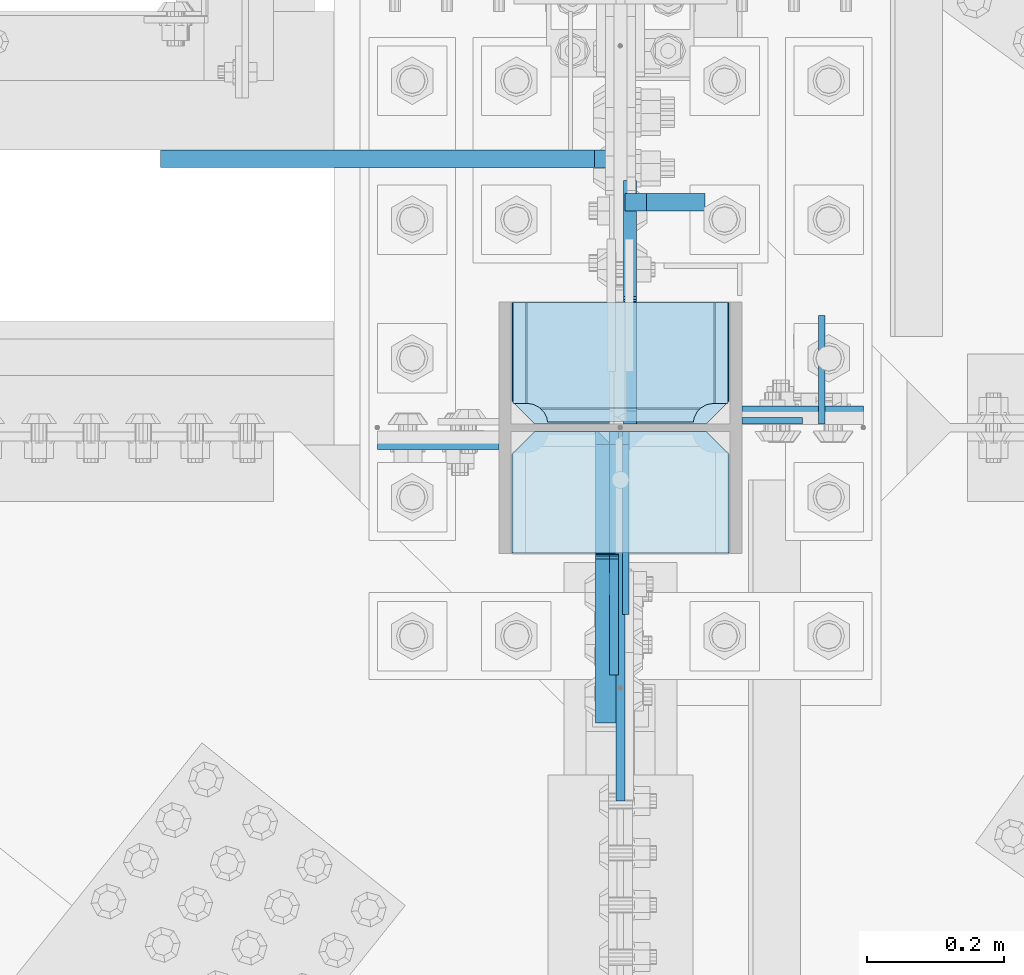
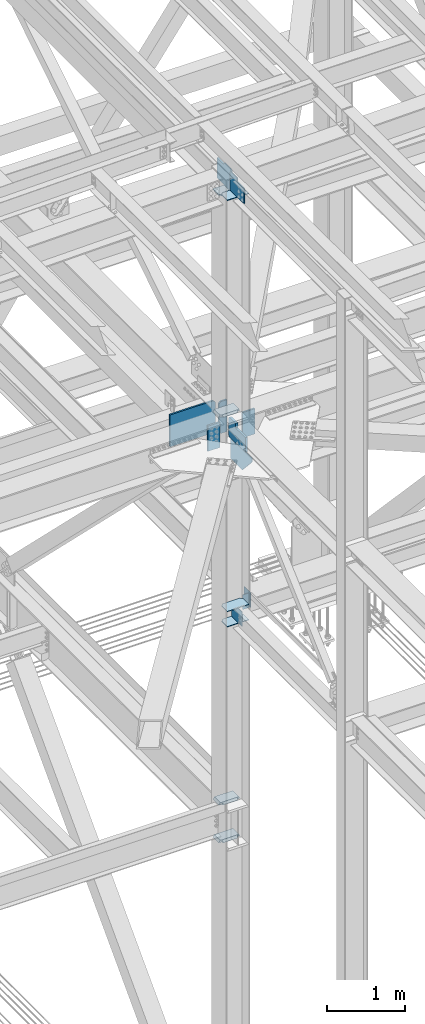
# One storey, part 3514 of 3843: 18 plates, 3 elements without a shape of their own.
"""IFC2X3 building model written with IfcOpenShell, lengths in millimetres."""

from ifc_helpers import new_model, si_unit, frame, origin_with_axes, place, context, subcontext, project, spatial, faceted_brep, material, type_object, element, aggregate, save


model = new_model("IFC2X3")

# Units and contexts
model_context = context("Model", 3, precision=1e-05, world=origin_with_axes())
body_context = subcontext(model_context, "Body", "Model", "MODEL_VIEW")
ifc_project = project(units=[si_unit("LENGTHUNIT", "METRE", prefix="MILLI"), si_unit("AREAUNIT", "SQUARE_METRE"), si_unit("VOLUMEUNIT", "CUBIC_METRE"), si_unit("MASSUNIT", "GRAM", prefix="KILO"), si_unit("TIMEUNIT", "SECOND"), si_unit("PLANEANGLEUNIT", "RADIAN"), si_unit("SOLIDANGLEUNIT", "STERADIAN"), si_unit("THERMODYNAMICTEMPERATUREUNIT", "DEGREE_CELSIUS"), si_unit("LUMINOUSINTENSITYUNIT", "LUMEN")], contexts=[model_context])

# Site, building, storey
site_placement = place(None, origin_with_axes())
site = spatial("IfcSite", under=ifc_project, at=site_placement, CompositionType="ELEMENT")
building_placement = place(site_placement, origin_with_axes())
building = spatial("IfcBuilding", under=site, at=building_placement, Name="Undefined", CompositionType="ELEMENT")
storey_placement = place(building_placement, origin_with_axes())
storey = spatial("IfcBuildingStorey", under=building, at=storey_placement, Name="Undefined", CompositionType="ELEMENT", Elevation=0.0)

# Assembly, plates
assembly_1_placement = place(storey_placement, origin_with_axes())
assembly_1 = element("IfcElementAssembly", 1, at=assembly_1_placement, inside=storey, Name="COLUMN", AssemblyPlace="NOTDEFINED", PredefinedType="RIGID_FRAME")
ifc_material = material(Name="STEEL/A572-50")
plate_type_1 = type_object("IfcPlateType", PredefinedType="NOTDEFINED")
plate_1_placement = place(assembly_1_placement, frame((76854.05, 92031.34375, 45946.8205507418), z_axis=(1.0, 0.0, 0.0), x_axis=(0.0, 1.0, 0.0)))
plate_1 = element("IfcPlate", 2, at=plate_1_placement, type_object=plate_type_1, material=ifc_material, Name="PLATE", context=body_context, shape_type="Brep", body=[
    faceted_brep([(0.0, -6.3499999046162, 0.0), (0.0, -6.34999999999854, 317.5), (0.0, 6.34999999999854, 317.5), (7.27595761418343e-12, 6.3499999046162, 0.0), (144.462501525879, -6.34999999999854, 317.5), (144.462501525879, 6.34999999999854, 317.5), (177.800003051758, -6.34999999999854, 284.162498474121), (177.800003051758, 6.34999999999854, 284.162498474121), (177.800003051758, -6.34999999999854, 33.3375015258789), (177.800003051758, 6.34999999999854, 33.3375015258789), (144.462501525879, -6.34999999999854, 0.0), (144.462501525879, 6.34999999999854, 0.0)], [[[0, 1, 2, 3]], [[1, 4, 5, 2]], [[4, 6, 7, 5]], [[6, 8, 9, 7]], [[8, 10, 11, 9]], [[10, 0, 3, 11]], [[5, 7, 9, 11, 3, 2]], [[10, 8, 6, 4, 1, 0]]]),
])
plate_type_2 = type_object("IfcPlateType", PredefinedType="NOTDEFINED")
plate_2_placement = place(assembly_1_placement, frame((76835.0, 92195.65, 42411.65), z_axis=(-1.0, 0.0, 0.0), x_axis=(0.0, 0.0, -1.0)))
plate_2 = element("IfcPlate", 3, at=plate_2_placement, type_object=plate_type_2, material=ifc_material, Name="PLATE", context=body_context, shape_type="Brep", body=[
    faceted_brep([(0.0, -12.6999999999971, 0.0), (4.36557456851006e-11, -12.7000000000171, 177.800000000003), (-1.45519152283669e-11, 12.7000000000025, 177.800000000003), (0.0, 12.6999999999971, 0.0), (393.700012207031, -12.7000000000007, 177.800003051758), (393.700012207031, 12.7000000000007, 177.800003051758), (393.700012207031, -12.7000000000007, 0.0), (393.700012207031, 12.7000000000007, 0.0)], [[[0, 1, 2, 3]], [[1, 4, 5, 2]], [[4, 6, 7, 5]], [[6, 0, 3, 7]], [[5, 7, 3, 2]], [[6, 4, 1, 0]]]),
])
plate_3_placement = place(assembly_1_placement, frame((77190.6, 92233.75, 42411.65), z_axis=(1.0, 0.0, 0.0), x_axis=(0.0, 0.0, -1.0)))
plate_3 = element("IfcPlate", 4, at=plate_3_placement, type_object=plate_type_2, material=ifc_material, Name="PLATE", context=body_context, shape_type="Brep", body=[
    faceted_brep([(0.0, -12.6999999999971, 0.0), (4.36557456851006e-11, -12.7000000000171, 177.800000000003), (-1.45519152283669e-11, 12.7000000000025, 177.800000000003), (0.0, 12.6999999999971, 0.0), (393.700012207031, -12.7000000000007, 177.800003051758), (393.700012207031, 12.7000000000007, 177.800003051758), (393.700012207031, -12.7000000000007, 0.0), (393.700012207031, 12.7000000000007, 0.0)], [[[0, 1, 2, 3]], [[1, 4, 5, 2]], [[4, 6, 7, 5]], [[6, 0, 3, 7]], [[5, 7, 3, 2]], [[6, 4, 1, 0]]]),
])
plate_type_3 = type_object("IfcPlateType", PredefinedType="NOTDEFINED")
plate_4_placement = place(assembly_1_placement, frame((77190.6, 92225.01875, 39573.2), z_axis=(1.0, 0.0, 0.0), x_axis=(0.0, 0.0, -1.0)))
plate_4 = element("IfcPlate", 5, at=plate_4_placement, type_object=plate_type_3, material=ifc_material, Name="PLATE", context=body_context, shape_type="Brep", body=[
    faceted_brep([(0.0, -4.76249999999709, 0.0), (0.0, -4.76249999999709, 88.9000015258789), (0.0, 4.76249999999709, 88.9000015258789), (0.0, 4.76249999999709, 0.0), (228.600006102781, -4.7625000004191, 88.9000015257589), (228.600006102781, 4.76249999954598, 88.9000015257443), (228.600006103079, -4.7625000004482, 7.27595761418343e-12), (228.600006103079, 4.76249999954598, -7.27595761418343e-12)], [[[0, 1, 2, 3]], [[1, 4, 5, 2]], [[4, 6, 7, 5]], [[6, 0, 3, 7]], [[5, 7, 3, 2]], [[6, 4, 1, 0]]]),
])
plate_type_4 = type_object("IfcPlateType", PredefinedType="NOTDEFINED")
plate_5_placement = place(assembly_1_placement, frame((76854.05, 92031.34375, 39308.0875), z_axis=(1.0, 0.0, 0.0), x_axis=(0.0, 1.0, 0.0)))
plate_5 = element("IfcPlate", 6, at=plate_5_placement, type_object=plate_type_4, material=ifc_material, Name="PLATE", context=body_context, shape_type="Brep", body=[
    faceted_brep([(0.0, -4.76249999999709, 0.0), (0.0, -4.76249999785796, 317.500000005042), (0.0, 4.76250000210712, 317.50000000505), (0.0, 4.76249999999709, 0.0), (144.462501525879, -4.76249999999709, 317.5), (144.462501525879, 4.76249999999709, 317.5), (177.800003051758, -4.76249999999709, 284.162498474121), (177.800003051758, 4.76249999999709, 284.162498474121), (177.800003051758, -4.76249999999709, 33.3375015258789), (177.800003051758, 4.76249999999709, 33.3375015258789), (144.462501525879, -4.76249999999709, 0.0), (144.462501525879, 4.76249999999709, 0.0)], [[[0, 1, 2, 3]], [[1, 4, 5, 2]], [[4, 6, 7, 5]], [[6, 8, 9, 7]], [[8, 10, 11, 9]], [[10, 0, 3, 11]], [[5, 7, 9, 11, 3, 2]], [[10, 8, 6, 4, 1, 0]]]),
])
plate_6_placement = place(assembly_1_placement, frame((76854.05, 92031.34375, 39546.2125), z_axis=(1.0, 0.0, 0.0), x_axis=(0.0, 1.0, 0.0)))
plate_6 = element("IfcPlate", 7, at=plate_6_placement, type_object=plate_type_4, material=ifc_material, Name="PLATE", context=body_context, shape_type="Brep", body=[
    faceted_brep([(0.0, -4.76249999999709, 0.0), (0.0, -4.76249999785796, 317.500000005042), (0.0, 4.76250000210712, 317.50000000505), (0.0, 4.76249999999709, 0.0), (144.462501525879, -4.76249999999709, 317.5), (144.462501525879, 4.76249999999709, 317.5), (177.800003051758, -4.76249999999709, 284.162498474121), (177.800003051758, 4.76249999999709, 284.162498474121), (177.800003051758, -4.76249999999709, 33.3375015258789), (177.800003051758, 4.76249999999709, 33.3375015258789), (144.462501525879, -4.76249999999709, 0.0), (144.462501525879, 4.76249999999709, 0.0)], [[[0, 1, 2, 3]], [[1, 4, 5, 2]], [[4, 6, 7, 5]], [[6, 8, 9, 7]], [[8, 10, 11, 9]], [[10, 0, 3, 11]], [[5, 7, 9, 11, 3, 2]], [[10, 8, 6, 4, 1, 0]]]),
])
plate_type_5 = type_object("IfcPlateType", PredefinedType="NOTDEFINED")
plate_7_placement = place(assembly_1_placement, frame((77173.1375, 92398.05625, 42452.925), z_axis=(-1.0, 0.0, 0.0), x_axis=(0.0, -1.0, 0.0)))
plate_7 = element("IfcPlate", 8, at=plate_7_placement, type_object=plate_type_5, material=ifc_material, Name="PLATE", context=body_context, shape_type="Brep", body=[
    faceted_brep([(160.070927103505, 9.33349681380787, 48.2144734940957), (156.294129000915, 15.875, 44.437675391513), (156.294129000915, 15.875, 276.23732460849), (160.070927103505, 9.33349681380787, 272.460526505907), (168.479274789282, -5.2299592362906, 268.176259371801), (174.625000047687, -15.875, 267.202872116366), (174.625000047687, -15.875, 53.4721278836369), (168.479274789282, -5.2299592362906, 52.4987406282016), (147.63749961853, 15.875, 21.5053709990898), (147.63749961853, -15.875, 3.17449995232164), (0.0, -15.875, 3.17449995232164), (0.0, 15.875, 21.5053709990898), (0.0, 15.875, 299.168629000924), (0.0, -15.875, 317.499500047692), (147.63749961853, -15.875, 317.499500047692), (147.63749961853, 15.875, 299.168629000924), (147.63749961853, -15.875, 296.862501907352), (147.63749961853, 15.875, 296.862501907352), (149.113757464445, -15.875, 287.541776696642), (149.113757464445, 15.875, 287.541776696642), (153.398024598548, -15.875, 279.133429010864), (153.398024598548, 15.875, 279.133429010864), (160.070927103505, -15.875, 272.460526505907), (168.479274789282, -15.875, 268.176259371801), (168.479274789282, -15.875, 52.4987406282016), (160.070927103505, -15.875, 48.2144734940957), (153.398024598548, -15.875, 41.5415709891386), (153.398024598548, 15.875, 41.5415709891386), (149.113757464449, -15.875, 33.1332233033609), (149.113757464449, 15.875, 33.1332233033609), (147.63749961853, -15.875, 23.8124980926514), (147.63749961853, 15.875, 23.8124980926514)], [[[0, 1, 2, 3, 4, 5, 6, 7]], [[8, 9, 10, 11]], [[12, 13, 14, 15]], [[13, 12, 11, 10]], [[16, 17, 15, 14]], [[16, 18, 19, 17]], [[18, 20, 21, 19]], [[21, 20, 22, 3, 2]], [[22, 23, 4, 3]], [[23, 5, 4]], [[24, 7, 6]], [[24, 25, 0, 7]], [[25, 26, 27, 1, 0]], [[26, 28, 29, 27]], [[28, 30, 31, 29]], [[31, 30, 9, 8]], [[27, 29, 31, 8, 11, 12, 15, 17, 19, 21, 2, 1]], [[9, 30, 28, 26, 25, 24, 6, 5, 23, 22, 20, 18, 16, 14, 13, 10]]]),
])
plate_type_6 = type_object("IfcPlateType", PredefinedType="NOTDEFINED")
plate_8_placement = place(assembly_1_placement, frame((77171.55, 92398.05625, 45902.4145639776), z_axis=(-1.0, 0.0, 0.0), x_axis=(0.0, -1.0, 0.0)))
plate_8 = element("IfcPlate", 9, at=plate_8_placement, type_object=plate_type_6, material=ifc_material, Name="PLATE", context=body_context, shape_type="Brep", body=[
    faceted_brep([(0.0, -9.52500000000146, 0.0), (0.0, -9.52500000000146, 317.5), (0.0, 9.52500000000146, 317.5), (0.0, 9.52500000000146, 0.0), (144.462501525879, -9.52500000000146, 317.5), (144.462501525879, 9.52500000000146, 317.5), (177.800003051758, -9.52500000000146, 284.162498474121), (177.800003051758, 9.52500000000146, 284.162498474121), (177.800003051758, -9.52500000000146, 33.3375015258789), (177.800003051758, 9.52500000000146, 33.3375015258789), (144.462501525879, -9.52500000000146, 0.0), (144.462501525879, 9.52500000000146, 0.0)], [[[0, 1, 2, 3]], [[1, 4, 5, 2]], [[4, 6, 7, 5]], [[6, 8, 9, 7]], [[8, 10, 11, 9]], [[10, 0, 3, 11]], [[5, 7, 9, 11, 3, 2]], [[10, 8, 6, 4, 1, 0]]]),
])
plate_type_7 = type_object("IfcPlateType", PredefinedType="NOTDEFINED")
plate_9_placement = place(assembly_1_placement, frame((77020.7375, 92209.14375, 39331.9), z_axis=(0.0, -0.707106781186682, 0.707106781186413), x_axis=(0.0, -0.707106781186548, -0.707106781186548)))
plate_9 = element("IfcPlate", 10, at=plate_9_placement, type_object=plate_type_7, material=ifc_material, Name="PLATE", context=body_context, shape_type="Brep", body=[
    faceted_brep([(0.0, -4.76249999999709, 0.0), (-134.703841815408, -4.76249999999709, 134.703841815382), (-134.703841815408, 4.76249999999709, 134.703841815382), (0.0, 4.76249999999709, 0.0), (-134.703841815266, -4.76249999999709, 161.644610178599), (-134.703841815266, 4.76249999999709, 161.644610178599), (40.9724185541018, -4.76249999999709, 337.320870548006), (40.9724185541018, 4.76249999999709, 337.320870548006), (202.617028732588, -4.76249999999709, 175.676260369546), (202.617028732588, 4.76249999999709, 175.676260369546), (26.9407683631998, -4.76249999999709, 1.30967237055302e-10), (26.9407683631998, 4.76249999999709, 1.30967237055302e-10)], [[[0, 1, 2, 3]], [[1, 4, 5, 2]], [[4, 6, 7, 5]], [[6, 8, 9, 7]], [[8, 10, 11, 9]], [[10, 0, 3, 11]], [[5, 7, 9, 11, 3, 2]], [[10, 8, 6, 4, 1, 0]]]),
])
plate_type_8 = type_object("IfcPlateType", PredefinedType="NOTDEFINED")
plate_10_placement = place(assembly_1_placement, frame((77173.1375, 92398.05625, 35831.4625), z_axis=(-1.0, 0.0, 0.0), x_axis=(0.0, -1.0, 0.0)))
plate_10 = element("IfcPlate", 11, at=plate_10_placement, type_object=plate_type_8, material=ifc_material, Name="PLATE", context=body_context, shape_type="Brep", body=[
    faceted_brep([(160.070930155271, 7.74588927352306, 48.2144734940957), (154.461042336727, 17.4625000000015, 42.6045856755663), (154.461042336727, 17.4625000000015, 278.070402117402), (160.070930155271, 7.74588927353034, 272.460514298873), (168.479277841048, -6.81779612594255, 268.176247164767), (174.625000047687, -17.4625000000015, 267.202860392674), (174.625000047687, -17.4625000000015, 53.472127400295), (168.479277841048, -6.81779612594255, 52.4987406282016), (147.637502670288, 17.4625000000015, 23.3384576632816), (147.637502670288, -17.4625000000015, 3.17449995232164), (0.0, -17.4625000000015, 3.17449995232164), (0.0, 17.4625000000015, 23.3384576632816), (0.0, 17.4625000000015, 297.335542336732), (0.0, -17.4625000000015, 317.499500047692), (147.637502670288, -17.4625000000015, 317.499500047692), (147.637502670288, 17.4625000000015, 297.335542336732), (147.637502670288, -17.4625000000015, 296.862489700317), (147.637502670288, 17.4625000000015, 296.862489700317), (149.113760516208, -17.4625000000015, 287.541764489608), (149.113760516208, 17.4625000000015, 287.541764489608), (153.398027650313, -17.4625000000015, 279.13341680383), (153.398027650313, 17.4625000000015, 279.13341680383), (160.070930155271, -17.4625000000015, 272.460514298873), (168.479277841048, -17.4625000000015, 268.176247164767), (168.479277841048, -17.4625000000015, 52.4987406282016), (160.070930155271, -17.4625000000015, 48.2144734940957), (153.398027650313, -17.4625000000015, 41.5415709891386), (153.398027650313, 17.4625000000015, 41.5415709891386), (149.113760516208, -17.4625000000015, 33.1332233033609), (149.113760516208, 17.4625000000015, 33.1332233033609), (147.637502670288, -17.4625000000015, 23.8124980926514), (147.637502670288, 17.4625000000015, 23.8124980926514)], [[[0, 1, 2, 3, 4, 5, 6, 7]], [[8, 9, 10, 11]], [[12, 13, 14, 15]], [[13, 12, 11, 10]], [[16, 17, 15, 14]], [[16, 18, 19, 17]], [[18, 20, 21, 19]], [[21, 20, 22, 3, 2]], [[22, 23, 4, 3]], [[23, 5, 4]], [[24, 7, 6]], [[24, 25, 0, 7]], [[25, 26, 27, 1, 0]], [[26, 28, 29, 27]], [[28, 30, 31, 29]], [[31, 30, 9, 8]], [[27, 29, 31, 8, 11, 12, 15, 17, 19, 21, 2, 1]], [[9, 30, 28, 26, 25, 24, 6, 5, 23, 22, 20, 18, 16, 14, 13, 10]]]),
])
plate_11_placement = place(assembly_1_placement, frame((77173.1375, 92398.05625, 36418.8375), z_axis=(-1.0, 0.0, 0.0), x_axis=(0.0, -1.0, 0.0)))
plate_11 = element("IfcPlate", 12, at=plate_11_placement, type_object=plate_type_8, material=ifc_material, Name="PLATE", context=body_context, shape_type="Brep", body=[
    faceted_brep([(160.070930155271, 7.74588927352306, 48.2144734940957), (154.461042336727, 17.4625000000015, 42.6045856755663), (154.461042336727, 17.4625000000015, 278.070402117402), (160.070930155271, 7.74588927353034, 272.460514298873), (168.479277841048, -6.81779612594255, 268.176247164767), (174.625000047687, -17.4625000000015, 267.202860392674), (174.625000047687, -17.4625000000015, 53.472127400295), (168.479277841048, -6.81779612594255, 52.4987406282016), (147.637502670288, 17.4625000000015, 23.3384576632816), (147.637502670288, -17.4625000000015, 3.17449995232164), (0.0, -17.4625000000015, 3.17449995232164), (0.0, 17.4625000000015, 23.3384576632816), (0.0, 17.4625000000015, 297.335542336732), (0.0, -17.4625000000015, 317.499500047692), (147.637502670288, -17.4625000000015, 317.499500047692), (147.637502670288, 17.4625000000015, 297.335542336732), (147.637502670288, -17.4625000000015, 296.862489700317), (147.637502670288, 17.4625000000015, 296.862489700317), (149.113760516208, -17.4625000000015, 287.541764489608), (149.113760516208, 17.4625000000015, 287.541764489608), (153.398027650313, -17.4625000000015, 279.13341680383), (153.398027650313, 17.4625000000015, 279.13341680383), (160.070930155271, -17.4625000000015, 272.460514298873), (168.479277841048, -17.4625000000015, 268.176247164767), (168.479277841048, -17.4625000000015, 52.4987406282016), (160.070930155271, -17.4625000000015, 48.2144734940957), (153.398027650313, -17.4625000000015, 41.5415709891386), (153.398027650313, 17.4625000000015, 41.5415709891386), (149.113760516208, -17.4625000000015, 33.1332233033609), (149.113760516208, 17.4625000000015, 33.1332233033609), (147.637502670288, -17.4625000000015, 23.8124980926514), (147.637502670288, 17.4625000000015, 23.8124980926514)], [[[0, 1, 2, 3, 4, 5, 6, 7]], [[8, 9, 10, 11]], [[12, 13, 14, 15]], [[13, 12, 11, 10]], [[16, 17, 15, 14]], [[16, 18, 19, 17]], [[18, 20, 21, 19]], [[21, 20, 22, 3, 2]], [[22, 23, 4, 3]], [[23, 5, 4]], [[24, 7, 6]], [[24, 25, 0, 7]], [[25, 26, 27, 1, 0]], [[26, 28, 29, 27]], [[28, 30, 31, 29]], [[31, 30, 9, 8]], [[27, 29, 31, 8, 11, 12, 15, 17, 19, 21, 2, 1]], [[9, 30, 28, 26, 25, 24, 6, 5, 23, 22, 20, 18, 16, 14, 13, 10]]]),
])
plate_type_9 = type_object("IfcPlateType", PredefinedType="NOTDEFINED")
plate_12_placement = place(assembly_1_placement, frame((77012.7999997492, 92209.1437500256, 42092.5625000007), z_axis=(0.0, 0.0, -1.0), x_axis=(0.0, -1.0, 0.0)))
plate_12 = element("IfcPlate", 13, at=plate_12_placement, type_object=plate_type_9, material=ifc_material, Name="PLATE", context=body_context, shape_type="Brep", body=[
    faceted_brep([(19.0499992370605, -6.34999999999854, 0.0), (0.0, -6.34999999999854, 19.0499992370605), (0.0, 6.34999999999854, 19.0499992370605), (19.0499992370605, 6.34999999999854, 0.0), (0.0, -6.35000000000582, 323.518849143686), (292.362207107595, -6.35000000000582, 323.518849143686), (292.362207107595, 6.35000000000582, 323.518849143686), (0.0, 6.35000000000582, 323.518849143686), (540.371308423739, -6.35000000000582, 51.2388908941648), (540.371308423739, 6.35000000000582, 51.2388908941648), (540.371308423739, -6.35000000000582, 0.0), (540.371308423739, 6.35000000000582, 0.0)], [[[0, 1, 2, 3]], [[4, 5, 6, 7]], [[5, 8, 9, 6]], [[8, 10, 11, 9]], [[11, 10, 0, 3]], [[7, 6, 9, 11, 3, 2]], [[4, 7, 2, 1]], [[10, 8, 5, 4, 1, 0]]]),
])
plate_type_10 = type_object("IfcPlateType", PredefinedType="NOTDEFINED")
plate_13_placement = place(assembly_1_placement, frame((76992.1625, 92209.14375, 42143.3625), z_axis=(0.0, -0.707106781186682, 0.707106781186413), x_axis=(0.0, -0.707106781186548, -0.707106781186548)))
plate_13 = element("IfcPlate", 14, at=plate_13_placement, type_object=plate_type_10, material=ifc_material, Name="PLATE", context=body_context, shape_type="Brep", body=[
    faceted_brep([(-187.462669209825, 15.875, 227.874176387639), (33.6761377704388, 15.875, 6.7353694073754), (26.9407683633472, 6.34991590662685, 2.7648638933897e-10), (0.0, -12.6997507629567, 7.27595761418343e-12), (-194.198038617193, -12.6997507629567, 194.198038617193), (-194.198038616931, 6.34991590662685, 221.138806980547), (0.0, -15.875, 0.0), (-194.198038617162, -15.875, 194.1980386172), (-194.198038617162, -15.875, 221.138806980285), (-81.3835710967596, -15.875, 333.953274500665), (-81.3835710967596, 15.875, 333.953274500665), (-37.6048223719172, -15.875, 290.174525775801), (-37.6048223719172, 15.875, 290.174525775801), (-33.4846459037744, -15.875, 287.421511875335), (-33.4846459037744, 15.875, 287.421511875335), (-28.6245663857389, -15.875, 286.454781952751), (-28.6245663857389, 15.875, 286.454781952751), (-23.7644868676998, -15.875, 287.421511875335), (-23.7644868676998, 15.875, 287.421511875335), (-19.6443103995607, -15.875, 290.174525775801), (-19.6443103995607, 15.875, 290.174525775801), (146.490427980447, -15.875, 456.30926415584), (146.490427980447, 15.875, 456.30926415584), (308.1350381589, -15.875, 294.664653977386), (308.1350381589, 15.875, 294.664653977386), (139.755235613762, -15.875, 126.284851432189), (139.755235613762, 15.875, 126.284851432189), (137.69047524009, -15.875, 123.194719158433), (137.69047524009, 15.875, 123.194719158433), (136.965427816298, -15.875, 119.549659611148), (136.965427816298, 15.875, 119.549659611148), (137.690475240086, -15.875, 115.904600063863), (137.690475240086, 15.875, 115.904600063863), (139.755235883486, -15.875, 112.814467520366), (139.755235883486, 15.875, 112.814467520366), (26.9407683630798, -15.875, 0.0)], [[[0, 1, 2, 3, 4, 5]], [[6, 7, 4, 3]], [[7, 8, 5, 4]], [[8, 9, 10, 0, 5]], [[9, 11, 12, 10]], [[11, 13, 14, 12]], [[13, 15, 16, 14]], [[15, 17, 18, 16]], [[17, 19, 20, 18]], [[19, 21, 22, 20]], [[21, 23, 24, 22]], [[23, 25, 26, 24]], [[25, 27, 28, 26]], [[27, 29, 30, 28]], [[29, 31, 32, 30]], [[31, 33, 34, 32]], [[34, 33, 35, 2, 1]], [[35, 6, 3, 2]], [[10, 12, 14, 16, 18, 20, 22, 24, 26, 28, 30, 32, 34, 1, 0]], [[35, 33, 31, 29, 27, 25, 23, 21, 19, 17, 15, 13, 11, 9, 8, 7, 6]]]),
])

# Assembly, plate
assembly_2_placement = place(storey_placement, origin_with_axes())
assembly_2 = element("IfcElementAssembly", 15, at=assembly_2_placement, inside=storey, Name="BEAM", AssemblyPlace="NOTDEFINED", PredefinedType="RIGID_FRAME")
plate_type_11 = type_object("IfcPlateType", PredefinedType="NOTDEFINED")
plate_14_placement = place(assembly_2_placement, frame((77307.28125, 92220.25625, 39570.025), z_axis=(0.0, 1.0, 0.0), x_axis=(0.0, 0.0, -1.0)))
plate_14 = element("IfcPlate", 16, at=plate_14_placement, type_object=plate_type_11, material=ifc_material, Name="PLATE", context=body_context, shape_type="Brep", body=[
    faceted_brep([(0.0, -4.76249999999709, 0.0), (0.0, -4.76249999999709, 158.749999526888), (0.0, 4.76249999999709, 158.749999526888), (0.0, 4.76249999999709, 0.0), (228.599999999999, -4.76249999999709, 158.749999526888), (228.599999999999, 4.76249999999709, 158.749999526888), (228.600006103079, -4.7625000004482, 7.27595761418343e-12), (228.600006103079, 4.76249999954598, -7.27595761418343e-12)], [[[0, 1, 2, 3]], [[1, 4, 5, 2]], [[4, 6, 7, 5]], [[6, 0, 3, 7]], [[5, 7, 3, 2]], [[6, 4, 1, 0]]]),
])
aggregate(assembly_2, [plate_14])

# Assembly, plates
assembly_3_placement = place(storey_placement, origin_with_axes())
assembly_3 = element("IfcElementAssembly", 17, at=assembly_3_placement, inside=storey, Name="BEAM", AssemblyPlace="NOTDEFINED", PredefinedType="RIGID_FRAME")
plate_type_12 = type_object("IfcPlateType", PredefinedType="NOTDEFINED")
plate_15_placement = place(assembly_3_placement, frame((77136.625, 92544.9, 41948.1), z_axis=(0.0, 0.0, 1.0), x_axis=(-1.0, 0.0, 0.0)))
plate_15 = element("IfcPlate", 18, at=plate_15_placement, type_object=plate_type_12, material=ifc_material, Name="STIFFENER", context=body_context, shape_type="Brep", body=[
    faceted_brep([(0.0, -12.6999999999971, 0.0), (0.0, -12.6999999999971, 498.474999999999), (0.0, 12.6999999999971, 498.474999999999), (0.0, 12.6999999999971, 0.0), (85.7249999999913, -12.6999999999971, 498.474999999999), (85.7249999999913, 12.6999999999971, 498.474999999999), (117.474999999991, -12.6999999999971, 466.724999999999), (117.474999999991, 12.6999999999971, 466.724999999999), (117.474999999991, -12.6999999999971, 31.75), (117.474999999991, 12.6999999999971, 31.75), (85.724990093946, -12.7000000000007, 2.3283064365387e-10), (85.724990093946, 12.7000000000007, 2.3283064365387e-10)], [[[0, 1, 2, 3]], [[1, 4, 5, 2]], [[4, 6, 7, 5]], [[6, 8, 9, 7]], [[8, 10, 11, 9]], [[10, 0, 3, 11]], [[5, 7, 9, 11, 3, 2]], [[10, 8, 6, 4, 1, 0]]]),
])
plate_type_13 = type_object("IfcPlateType", PredefinedType="NOTDEFINED")
plate_16_placement = place(assembly_3_placement, frame((77006.45, 92608.4, 41948.1), z_axis=(0.0, 0.0, 1.0), x_axis=(-1.0, 0.0, 0.0)))
plate_16 = element("IfcPlate", 19, at=plate_16_placement, type_object=plate_type_13, material=ifc_material, Name="STIFFENER", context=body_context, shape_type="Brep", body=[
    faceted_brep([(0.0, -12.7000000000262, 31.7500000000218), (0.0, -12.6999999999971, 466.724999999999), (0.0, 12.6999999999971, 466.724999999999), (0.0, 12.699999999837, 31.75000000008), (31.75, -12.6999999999971, 498.474999999999), (31.75, 12.6999999999971, 498.474999999999), (666.749999999985, -12.6999999999971, 498.474999999999), (666.749999999985, 12.6999999999971, 498.474999999999), (666.749999999985, -12.6999999999971, 0.0), (666.749999999985, 12.6999999999971, 0.0), (31.75, -12.6999999999389, -2.91038304567337e-11), (31.75, 12.6999999999098, 2.91038304567337e-11)], [[[0, 1, 2, 3]], [[1, 4, 5, 2]], [[4, 6, 7, 5]], [[6, 8, 9, 7]], [[8, 10, 11, 9]], [[10, 0, 3, 11]], [[5, 7, 9, 11, 3, 2]], [[10, 8, 6, 4, 1, 0]]]),
])
aggregate(assembly_3, [plate_15, plate_16])

# Plate
plate_type_14 = type_object("IfcPlateType", PredefinedType="NOTDEFINED")
plate_17_placement = place(assembly_1_placement, frame((77003.2750002455, 92209.14375, 45972.2205507418), z_axis=(0.0, -0.707106781186682, 0.707106781186413), x_axis=(0.0, -0.707106781186548, -0.707106781186548)))
plate_17 = element("IfcPlate", 20, at=plate_17_placement, type_object=plate_type_14, material=ifc_material, Name="PLATE", context=body_context, shape_type="Brep", body=[
    faceted_brep([(0.0, -6.3499999046162, 0.0), (-186.340314511304, -6.35000000000582, 186.340314511268), (-186.340314511304, 6.35000000000582, 186.340314511268), (7.27595761418343e-12, 6.3499999046162, 0.0), (-186.340314511177, -6.35000000000582, 213.281082874484), (-186.340314511177, 6.35000000000582, 213.281082874484), (-73.5258469896398, -6.35000000000582, 326.095550396043), (-73.5258469896398, 6.35000000000582, 326.095550396043), (-39.8498864009416, -6.35000000000582, 292.419589807352), (-39.8498864009416, 6.35000000000582, 292.419589807352), (-35.7297099327989, -6.35000000000582, 289.666575906886), (-35.7297099327989, 6.35000000000582, 289.666575906886), (-30.8696304147634, -6.35000000000582, 288.699845984302), (-30.8696304147634, 6.35000000000582, 288.699845984302), (-26.0095508967242, -6.35000000000582, 289.666575906886), (-26.0095508967242, 6.35000000000582, 289.666575906886), (-21.8893744285815, -6.35000000000582, 292.419589807352), (-21.8893744285815, 6.35000000000582, 292.419589807352), (94.853955280887, -6.35000000000582, 409.16291951685), (94.853955280887, 6.35000000000582, 409.16291951685), (265.478821582976, -6.35000000000582, 238.538053219985), (265.478821582976, 6.35000000000582, 238.538053219985), (26.9407683632217, -6.34999999999854, 1.30967237055302e-10), (26.9407683632217, 6.34999999999854, 1.30967237055302e-10)], [[[0, 1, 2, 3]], [[1, 4, 5, 2]], [[4, 6, 7, 5]], [[6, 8, 9, 7]], [[8, 10, 11, 9]], [[10, 12, 13, 11]], [[12, 14, 15, 13]], [[14, 16, 17, 15]], [[16, 18, 19, 17]], [[18, 20, 21, 19]], [[20, 22, 23, 21]], [[22, 0, 3, 23]], [[5, 7, 9, 11, 13, 15, 17, 19, 21, 23, 3, 2]], [[22, 20, 18, 16, 14, 12, 10, 8, 6, 4, 1, 0]]]),
])

plate_type_15 = type_object("IfcPlateType", PredefinedType="NOTDEFINED")
plate_18_placement = place(assembly_1_placement, frame((77027.0875003815, 92220.25625, 45930.9895639774), z_axis=(0.0, 0.707106781186548, 0.707106781186548), x_axis=(5.70000238222118e-08, 0.707106781186546, -0.707106781186546)))
plate_18 = element("IfcPlate", 21, at=plate_18_placement, type_object=plate_type_15, material=ifc_material, Name="PLATE", context=body_context, shape_type="Brep", body=[
    faceted_brep([(0.0, -9.52500000000146, 0.0), (-214.403614889528, -9.52499999999418, 214.403614889488), (-214.403614889528, 9.52499999999418, 214.403614889488), (0.0, 9.52500000000146, 0.0), (-214.403614889336, -9.52499999999418, 241.344383252748), (-214.403614889336, 9.52499999999418, 241.344383252748), (-101.589147367522, -9.52499999999418, 354.158850774584), (-101.589147367522, 9.52499999999418, 354.158850774584), (-93.731422658424, -9.52499999999418, 346.301126065489), (-93.731422658424, 9.52499999999418, 346.301126065489), (-89.6112461902703, -9.52499999999418, 343.548112165008), (-89.6112461902703, 9.52499999999418, 343.548112165008), (-84.7511666722385, -9.52499999999418, 342.581382242439), (-84.7511666722385, 9.52499999999418, 342.581382242439), (-79.8910871541921, -9.52499999999418, 343.548112165023), (-79.8910871541921, 9.52499999999418, 343.548112165023), (-75.770910686042, -9.52499999999418, 346.301126065511), (-75.770910686042, 9.52499999999418, 346.301126065511), (40.9724185538689, -9.52500000000146, 463.044456243078), (40.9724185538689, 9.52500000000146, 463.044456243078), (265.478821579974, -9.52500000000146, 238.538053217882), (265.478821579974, 9.52500000000146, 238.538053217882), (26.9407683632344, -9.52499999999964, 2.03726813197136e-10), (26.9407683632344, 9.52499999999964, 2.03726813197136e-10)], [[[0, 1, 2, 3]], [[1, 4, 5, 2]], [[4, 6, 7, 5]], [[6, 8, 9, 7]], [[8, 10, 11, 9]], [[10, 12, 13, 11]], [[12, 14, 15, 13]], [[14, 16, 17, 15]], [[16, 18, 19, 17]], [[18, 20, 21, 19]], [[20, 22, 23, 21]], [[22, 0, 3, 23]], [[5, 7, 9, 11, 13, 15, 17, 19, 21, 23, 3, 2]], [[22, 20, 18, 16, 14, 12, 10, 8, 6, 4, 1, 0]]]),
])

aggregate(assembly_1, [plate_5, plate_6, plate_9, plate_12, plate_13, plate_7, plate_2, plate_3, plate_8, plate_18, plate_1, plate_17, plate_4, plate_10, plate_11])

save(model, "model.ifc")
